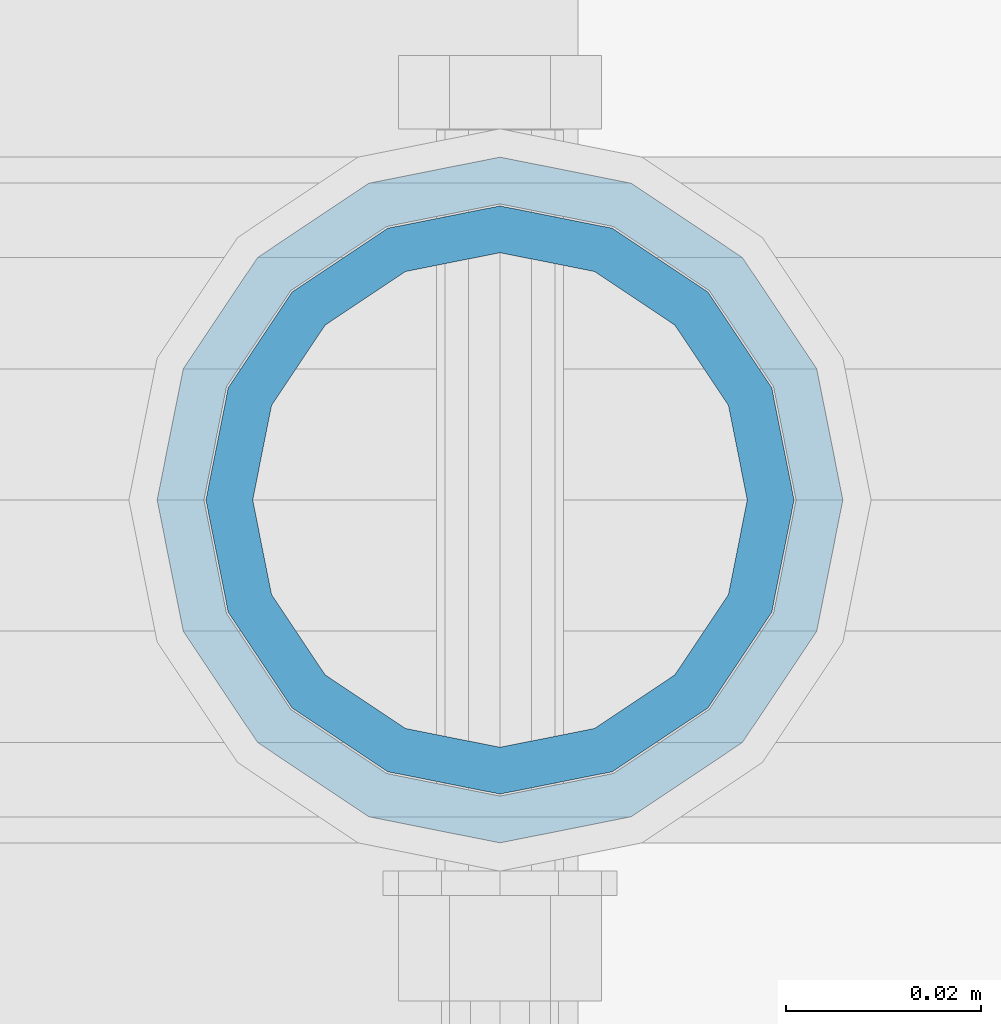
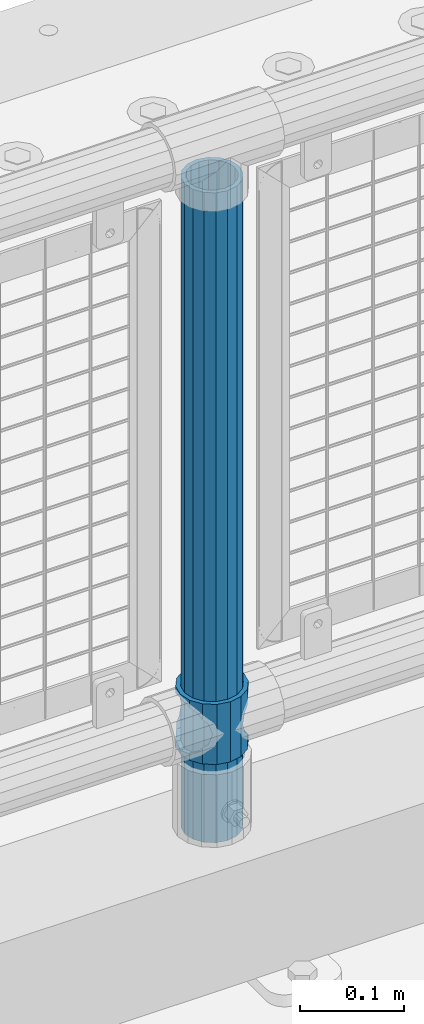
# One storey, part 88 of 242: 2 columns.
"""IFC2X3 building model written with IfcOpenShell, lengths in millimetres."""

from ifc_helpers import new_model, si_unit, frame, origin_with_axes, place, context, subcontext, project, spatial, faceted_brep, material, type_object, element, save


model = new_model("IFC2X3")

# Units and contexts
model_context = context("Model", 3, precision=1e-05, world=origin_with_axes())
body_context = subcontext(model_context, "Body", "Model", "MODEL_VIEW")
ifc_project = project(units=[si_unit("LENGTHUNIT", "METRE", prefix="MILLI"), si_unit("AREAUNIT", "SQUARE_METRE"), si_unit("VOLUMEUNIT", "CUBIC_METRE"), si_unit("MASSUNIT", "GRAM", prefix="KILO"), si_unit("TIMEUNIT", "SECOND"), si_unit("PLANEANGLEUNIT", "RADIAN"), si_unit("SOLIDANGLEUNIT", "STERADIAN"), si_unit("THERMODYNAMICTEMPERATUREUNIT", "DEGREE_CELSIUS"), si_unit("LUMINOUSINTENSITYUNIT", "LUMEN")], contexts=[model_context])

# Site, building, storey
site_placement = place(None, origin_with_axes())
site = spatial("IfcSite", under=ifc_project, at=site_placement, CompositionType="ELEMENT")
building_placement = place(site_placement, origin_with_axes())
building = spatial("IfcBuilding", under=site, at=building_placement, Name="Standard", CompositionType="ELEMENT")
storey_placement = place(building_placement, origin_with_axes())
storey = spatial("IfcBuildingStorey", under=building, at=storey_placement, Name="Undefined", CompositionType="ELEMENT", Elevation=0.0)

# Columns
ifc_material_1 = material()
column_type_1 = type_object("IfcColumnType", PredefinedType="NOTDEFINED")
column_1_placement = place(storey_placement, frame((-30398.0, -19335.5, 168.02), z_axis=(-1.0, 0.0, 0.0), x_axis=(0.0, 0.0, 1.0)))
element("IfcColumn", 1, at=column_1_placement, inside=storey, type_object=column_type_1, material=ifc_material_1, context=body_context, shape_type="Brep", body=[
    faceted_brep([(0.0, -25.3499999999985, 0.0), (0.0, -23.4203461491597, 9.70102501045403), (760.0, -23.4203461491597, 9.70102501045403), (760.0, -25.3499999999985, 0.0), (0.0, -17.9251569030785, 17.9251569030785), (760.0, -17.9251569030785, 17.9251569030785), (0.0, -9.70102501045403, 23.4203461491597), (760.0, -9.70102501045403, 23.4203461491597), (0.0, 0.0, 25.3499999999985), (760.0, 0.0, 25.3499999999985), (0.0, 9.70102501045403, 23.4203461491597), (760.0, 9.70102501045403, 23.4203461491597), (0.0, 17.9251569030785, 17.9251569030785), (760.0, 17.9251569030785, 17.9251569030785), (0.0, 23.4203461491597, 9.70102501045403), (760.0, 23.4203461491597, 9.70102501045403), (0.0, 25.3499999999985, 0.0), (760.0, 25.3499999999985, 0.0), (0.0, 23.4203461491597, -9.70102501045403), (760.0, 23.4203461491597, -9.70102501045403), (0.0, 17.9251569030785, -17.9251569030785), (760.0, 17.9251569030785, -17.9251569030785), (0.0, 9.70102501045403, -23.4203461491597), (760.0, 9.70102501045403, -23.4203461491597), (0.0, 0.0, -25.3499999999985), (760.0, 0.0, -25.3499999999985), (0.0, -9.70102501045403, -23.4203461491597), (760.0, -9.70102501045403, -23.4203461491597), (0.0, -17.9251569030785, -17.9251569030785), (760.0, -17.9251569030785, -17.9251569030785), (0.0, -23.4203461491597, -9.70102501045403), (760.0, -23.4203461491597, -9.70102501045403), (0.0, -30.1500000000015, 0.0), (0.0, -27.8549679052157, -11.5379054858058), (760.0, -27.8549679052157, -11.5379054858058), (760.0, -30.1500000000015, 0.0), (0.0, -21.3192694527752, -21.3192694527752), (760.0, -21.3192694527752, -21.3192694527752), (0.0, -11.5379054858058, -27.8549679052157), (760.0, -11.5379054858058, -27.8549679052157), (0.0, 0.0, -30.1500000000015), (760.0, 0.0, -30.1500000000015), (0.0, 11.5379054858058, -27.8549679052157), (760.0, 11.5379054858058, -27.8549679052157), (0.0, 21.3192694527752, -21.3192694527752), (760.0, 21.3192694527752, -21.3192694527752), (0.0, 27.8549679052157, -11.5379054858058), (760.0, 27.8549679052157, -11.5379054858058), (0.0, 30.1500000000015, 0.0), (760.0, 30.1500000000015, 0.0), (0.0, 27.8549679052157, 11.5379054858058), (760.0, 27.8549679052157, 11.5379054858058), (0.0, 21.3192694527752, 21.3192694527752), (760.0, 21.3192694527752, 21.3192694527752), (0.0, 11.5379054858058, 27.8549679052157), (760.0, 11.5379054858058, 27.8549679052157), (0.0, 0.0, 30.1500000000015), (760.0, 0.0, 30.1500000000015), (0.0, -11.5379054858058, 27.8549679052157), (760.0, -11.5379054858058, 27.8549679052157), (0.0, -21.3192694527752, 21.3192694527752), (760.0, -21.3192694527752, 21.3192694527752), (0.0, -27.8549679052157, 11.5379054858058), (760.0, -27.8549679052157, 11.5379054858058)], [[[0, 1, 2, 3]], [[1, 4, 5, 2]], [[4, 6, 7, 5]], [[6, 8, 9, 7]], [[8, 10, 11, 9]], [[10, 12, 13, 11]], [[12, 14, 15, 13]], [[14, 16, 17, 15]], [[16, 18, 19, 17]], [[18, 20, 21, 19]], [[20, 22, 23, 21]], [[22, 24, 25, 23]], [[24, 26, 27, 25]], [[26, 28, 29, 27]], [[28, 30, 31, 29]], [[30, 0, 3, 31]], [[32, 33, 34, 35]], [[33, 36, 37, 34]], [[36, 38, 39, 37]], [[38, 40, 41, 39]], [[40, 42, 43, 41]], [[42, 44, 45, 43]], [[44, 46, 47, 45]], [[46, 48, 49, 47]], [[48, 50, 51, 49]], [[50, 52, 53, 51]], [[52, 54, 55, 53]], [[54, 56, 57, 55]], [[56, 58, 59, 57]], [[58, 60, 61, 59]], [[60, 62, 63, 61]], [[62, 32, 35, 63]], [[37, 39, 41, 43, 45, 47, 49, 51, 53, 55, 57, 59, 61, 63, 35, 34], [5, 7, 9, 11, 13, 15, 17, 19, 21, 23, 25, 27, 29, 31, 3, 2]], [[62, 60, 58, 56, 54, 52, 50, 48, 46, 44, 42, 40, 38, 36, 33, 32], [30, 28, 26, 24, 22, 20, 18, 16, 14, 12, 10, 8, 6, 4, 1, 0]]]),
])
ifc_material_2 = material(Name="Misc_Undefined")
column_type_2 = type_object("IfcColumnType", PredefinedType="NOTDEFINED")
column_2_placement = place(storey_placement, frame((-30398.0, -19335.5, 263.02), z_axis=(-1.0, 0.0, 0.0), x_axis=(0.0, 0.0, 1.0)))
element("IfcColumn", 2, at=column_2_placement, inside=storey, type_object=column_type_2, material=ifc_material_2, context=body_context, shape_type="Brep", body=[
    faceted_brep([(63.1897438117172, 11.614442172282, -32.8397438117245), (63.1897438117172, 11.614442172282, -28.0397438117143), (56.6106908090114, 21.46069080901, -21.4606908090136), (56.6106908090114, 21.46069080901, -27.1226768591077), (61.9623795176744, 13.4513226476338, -32.4743655677739), (46.7644421722801, 28.0397438117179, -11.6144421722784), (46.7644421722801, 28.0397438117179, -20.0882031229849), (51.5310424080006, 24.8548033587067, -24.8548033587067), (35.1500000000015, 30.35, 0.0), (35.1499999999996, 30.3499999999985, -16.6306603983685), (23.5355578277192, 28.0397438117179, -11.6144421722784), (23.5355578277192, 28.0397438117179, -20.0882031229849), (18.7689575919987, 24.8548033587067, -24.8548033587067), (13.6893091909879, 21.46069080901, -21.4606908090136), (13.6893091909879, 21.46069080901, -27.1226768591077), (8.33762048232262, 13.4513226476338, -32.4743655677739), (7.11025618828211, 11.614442172282, -28.0397438117143), (7.11025618828211, 11.614442172282, -32.8397438117245), (4.79999999999961, 0.0, -30.3499999999985), (4.79999999999961, 0.0, -35.1500000000015), (7.11025618828211, -11.614442172282, -28.0397438117143), (7.11025618828211, -11.614442172282, -32.8397438117172), (13.6893091909879, -21.46069080901, -21.4606908090136), (13.6893091909879, -21.46069080901, -27.1226768591077), (8.33762048232484, -13.4513226476338, -32.4743655677739), (23.5355578277191, -28.0397438117179, -11.6144421722784), (23.5355578277191, -28.0397438117179, -20.0882031229921), (18.7689575919975, -24.8548033587067, -24.8548033587067), (35.1500000000015, -30.35, 0.0), (35.1499999999996, -30.3499999999985, -16.6306603983758), (46.7644421722801, -28.0397438117179, -11.6144421722784), (46.7644421722801, -28.0397438117179, -20.0882031229921), (51.5310424079973, -24.8548033587067, -24.8548033587067), (56.6106908090114, -21.46069080901, -21.4606908090136), (56.6106908090114, -21.46069080901, -27.1226768591077), (61.9623795176767, -13.4513226476338, -32.4743655677739), (63.1897438117172, -11.614442172282, -28.0397438117143), (63.1897438117172, -11.614442172282, -32.8397438117172), (65.4999999999997, 0.0, -30.3499999999985), (65.4999999999997, 0.0, -35.1500000000015), (0.0, -28.0397438117179, -11.6144421722784), (0.0, -30.3499999999985, 0.0), (0.0, -21.46069080901, -21.4606908090136), (0.0, -11.614442172282, -28.0397438117143), (0.0, 0.0, -30.3499999999985), (0.0, 11.614442172282, -28.0397438117143), (0.0, 21.46069080901, -21.4606908090136), (0.0, 28.0397438117179, -11.6144421722784), (0.0, 30.3499999999985, 0.0), (0.0, 28.0397438117179, 11.6144421722784), (23.5355578277192, 28.0397438117179, 11.614442172282), (0.0, 21.46069080901, 21.4606908090136), (13.6893091909879, 21.46069080901, 21.46069080901), (0.0, 11.614442172282, 28.0397438117143), (7.11025618828211, 11.614442172282, 28.0397438117179), (0.0, 0.0, 30.3499999999985), (4.79999999999961, 0.0, 30.3499999999985), (0.0, -11.614442172282, 28.0397438117143), (7.11025618828205, -11.614442172282, 28.0397438117179), (0.0, -21.46069080901, 21.4606908090136), (13.6893091909879, -21.46069080901, 21.46069080901), (0.0, -28.0397438117179, 11.6144421722784), (23.5355578277191, -28.0397438117179, 11.614442172282), (0.0, -32.4743655677703, 13.4513226476338), (0.0, -35.1500000000015, 0.0), (70.2999999999993, -35.1500000000015, 0.0), (70.2999999999993, -32.4743655677703, 13.4513226476338), (0.0, 13.4513226476338, -32.4743655677739), (0.0, 24.8548033587067, -24.8548033587067), (0.0, 0.0, -35.1500000000015), (0.0, -13.4513226476338, -32.4743655677739), (0.0, -24.8548033587067, -24.8548033587067), (0.0, -24.8548033587067, 24.8548033587067), (0.0, -13.4513226476338, 32.4743655677739), (0.0, 0.0, 35.1500000000015), (0.0, 13.4513226476338, 32.4743655677739), (0.0, 24.8548033587067, 24.8548033587067), (0.0, 32.4743655677703, 13.4513226476338), (0.0, 35.1500000000015, 0.0), (0.0, 32.4743655677703, -13.4513226476338), (0.0, -32.4743655677703, -13.4513226476338), (70.2999999999993, 32.4743655677703, 13.4513226476338), (70.2999999999993, 35.1500000000015, 0.0), (70.2999999999993, 32.4743655677703, -13.4513226476338), (70.2999999999993, 24.8548033587067, -24.8548033587067), (70.2999999999993, 13.4513226476338, -32.4743655677739), (70.2999999999993, 0.0, -35.1500000000015), (70.2999999999993, -13.4513226476338, -32.4743655677739), (70.2999999999993, -24.8548033587067, -24.8548033587067), (70.2999999999993, -32.4743655677703, -13.4513226476338), (70.2999999999993, 28.0397438117179, 11.6144421722784), (70.2999999999993, 21.46069080901, 21.4606908090136), (56.6106908090114, 21.46069080901, 21.46069080901), (46.7644421722801, 28.0397438117179, 11.614442172282), (70.2999999999993, 11.614442172282, 28.0397438117143), (63.1897438117172, 11.614442172282, 28.0397438117179), (70.2999999999993, 0.0, 30.3499999999985), (65.4999999999997, 0.0, 30.3499999999985), (70.2999999999993, -11.614442172282, 28.0397438117143), (63.1897438117172, -11.614442172282, 28.0397438117179), (70.2999999999993, -21.46069080901, 21.4606908090136), (56.6106908090114, -21.46069080901, 21.46069080901), (70.2999999999993, -28.0397438117179, 11.6144421722784), (46.7644421722801, -28.0397438117179, 11.614442172282), (70.2999999999993, -11.614442172282, -28.0397438117143), (70.2999999999993, 0.0, -30.3499999999985), (70.2999999999993, -21.46069080901, -21.4606908090136), (70.2999999999993, -28.0397438117179, -11.6144421722784), (70.2999999999993, -30.3499999999985, 0.0), (70.2999999999993, 24.8548033587067, 24.8548033587067), (70.2999999999993, 13.4513226476338, 32.4743655677739), (70.2999999999993, 0.0, 35.1500000000015), (70.2999999999993, -13.4513226476338, 32.4743655677739), (70.2999999999993, -24.8548033587067, 24.8548033587067), (70.2999999999993, 30.3499999999985, 0.0), (70.2999999999993, 28.0397438117179, -11.6144421722784), (70.2999999999993, 21.46069080901, -21.4606908090136), (70.2999999999993, 11.614442172282, -28.0397438117143), (61.9623795176744, 13.4513226476338, 32.4743655677703), (51.5310424080006, 24.8548033587067, 24.8548033587067), (56.6106908090114, 21.46069080901, 27.1226768591077), (65.4999999999997, 0.0, 35.1500000000015), (63.1897438117172, 11.614442172282, 32.8397438117136), (63.1897438117172, -11.614442172282, 32.8397438117172), (61.9623795176767, -13.4513226476338, 32.4743655677703), (56.6106908090114, -21.46069080901, 27.1226768591077), (51.5310424080038, -24.8548033587067, 24.8548033587067), (18.7689575919954, -24.8548033587067, 24.8548033587067), (46.7644421722801, -28.0397438117179, 20.0882031229885), (35.1499999999996, -30.3499999999985, 16.6306603983685), (23.5355578277191, -28.0397438117179, 20.0882031229885), (8.33762048232484, -13.4513226476338, 32.4743655677703), (13.6893091909879, -21.46069080901, 27.1226768591077), (4.79999999999961, 0.0, 35.1500000000015), (7.11025618828205, -11.614442172282, 32.8397438117172), (7.11025618828211, 11.614442172282, 32.8397438117136), (8.33762048232262, 13.4513226476338, 32.4743655677703), (13.6893091909879, 21.46069080901, 27.1226768591077), (18.768957592002, 24.8548033587067, 24.8548033587067), (23.5355578277192, 28.0397438117179, 20.0882031229812), (35.1499999999996, 30.3499999999985, 16.6306603983721), (46.7644421722801, 28.0397438117179, 20.0882031229812)], [[[0, 1, 2, 3, 4]], [[3, 2, 5, 6, 7]], [[6, 5, 8, 9]], [[9, 8, 10, 11]], [[12, 11, 10, 13, 14]], [[15, 14, 13, 16, 17]], [[17, 16, 18, 19]], [[19, 18, 20, 21]], [[21, 20, 22, 23, 24]], [[23, 22, 25, 26, 27]], [[26, 25, 28, 29]], [[29, 28, 30, 31]], [[32, 31, 30, 33, 34]], [[35, 34, 33, 36, 37]], [[37, 36, 38, 39]], [[39, 38, 1, 0]], [[40, 41, 28, 25]], [[42, 40, 25, 22]], [[43, 42, 22, 20]], [[44, 43, 20, 18]], [[45, 44, 18, 16]], [[46, 45, 16, 13]], [[47, 46, 13, 10]], [[48, 47, 10, 8]], [[49, 48, 8, 50]], [[51, 49, 50, 52]], [[53, 51, 52, 54]], [[55, 53, 54, 56]], [[57, 55, 56, 58]], [[59, 57, 58, 60]], [[61, 59, 60, 62]], [[41, 61, 62, 28]], [[63, 64, 65, 66]], [[67, 68, 12, 14, 15]], [[69, 67, 15, 17, 19]], [[24, 70, 69, 19, 21]], [[27, 71, 70, 24, 23]], [[63, 72, 73, 74, 75, 76, 77, 78, 79, 68, 67, 69, 70, 71, 80, 64], [40, 42, 43, 44, 45, 46, 47, 48, 49, 51, 53, 55, 57, 59, 61, 41]], [[78, 77, 81, 82]], [[79, 78, 82, 83]], [[68, 79, 83, 84, 7, 6, 9, 11, 12]], [[7, 84, 85, 4, 3]], [[4, 85, 86, 39, 0]], [[87, 88, 32, 34, 35]], [[86, 87, 35, 37, 39]], [[29, 31, 32, 88, 89, 80, 71, 27, 26]], [[64, 80, 89, 65]], [[90, 91, 92, 93]], [[91, 94, 95, 92]], [[94, 96, 97, 95]], [[96, 98, 99, 97]], [[98, 100, 101, 99]], [[100, 102, 103, 101]], [[104, 105, 38, 36]], [[106, 104, 36, 33]], [[107, 106, 33, 30]], [[108, 107, 30, 28]], [[102, 108, 28, 103]], [[88, 87, 86, 85, 84, 83, 82, 81, 109, 110, 111, 112, 113, 66, 65, 89], [100, 98, 96, 94, 91, 90, 114, 115, 116, 117, 105, 104, 106, 107, 108, 102]], [[118, 110, 109, 119, 120]], [[121, 111, 110, 118, 122]], [[112, 111, 121, 123, 124]], [[113, 112, 124, 125, 126]], [[127, 72, 63, 66, 113, 126, 128, 129, 130]], [[131, 73, 72, 127, 132]], [[133, 74, 73, 131, 134]], [[75, 74, 133, 135, 136]], [[76, 75, 136, 137, 138]], [[119, 109, 81, 77, 76, 138, 139, 140, 141]], [[92, 120, 119, 141, 93]], [[95, 122, 118, 120, 92]], [[97, 121, 122, 95]], [[99, 123, 121, 97]], [[101, 125, 124, 123, 99]], [[103, 128, 126, 125, 101]], [[28, 129, 128, 103]], [[62, 130, 129, 28]], [[60, 132, 127, 130, 62]], [[58, 134, 131, 132, 60]], [[56, 133, 134, 58]], [[54, 135, 133, 56]], [[52, 137, 136, 135, 54]], [[50, 139, 138, 137, 52]], [[8, 140, 139, 50]], [[93, 141, 140, 8]], [[114, 90, 93, 8]], [[115, 114, 8, 5]], [[116, 115, 5, 2]], [[117, 116, 2, 1]], [[105, 117, 1, 38]]]),
])

save(model, "model.ifc")
